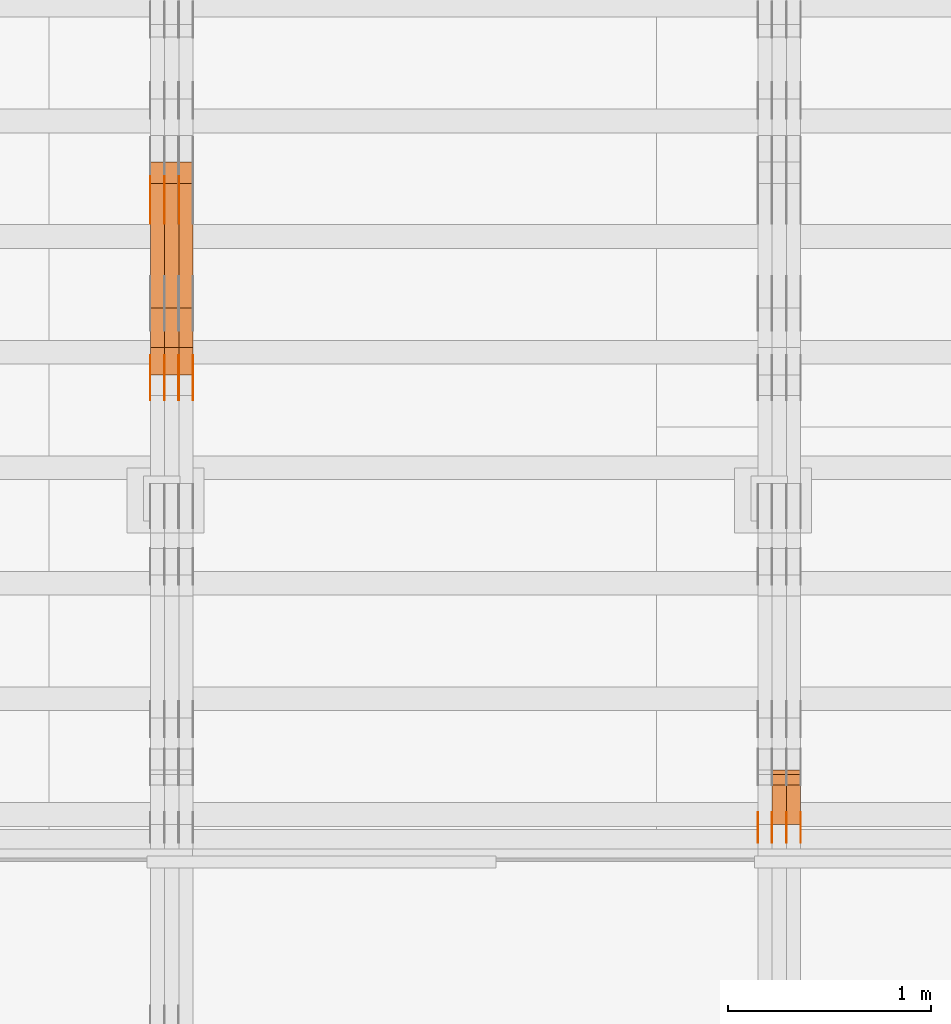
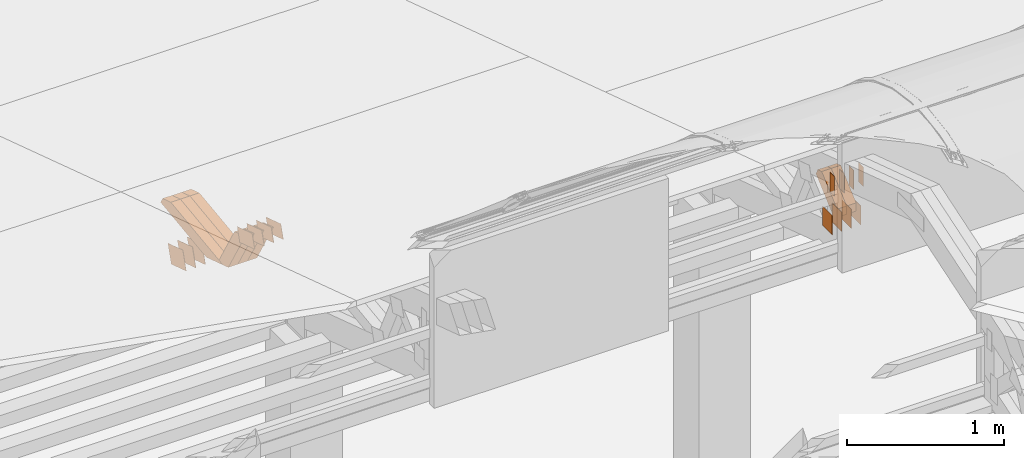
# One storey, part 166 of 385: 30 proxies.
"""IFC2X3 building model written with IfcOpenShell, lengths in millimetres."""

from ifc_helpers import new_model, entity, si_unit, converted_unit, derived_unit, direction, frame, origin, origin_2d_with_axis, place, context, subcontext, project, spatial, polyline, rectangle, outline, extrude, source, transform, mapped, material, type_object, type_shapes, element, save


model = new_model("IFC2X3")

# Units and contexts
model_context = context("Model", 3, precision=0.01, world=origin(), true_north=direction((6.12303176911189e-17, 1.0)))
body_context = subcontext(model_context, "Body", "Model", "MODEL_VIEW")
ifc_project = project(units=[si_unit("LENGTHUNIT", "METRE", prefix="MILLI"), si_unit("AREAUNIT", "SQUARE_METRE"), si_unit("VOLUMEUNIT", "CUBIC_METRE"), converted_unit("PLANEANGLEUNIT", "DEGREE", entity("IfcRatioMeasure", 0.0174532925199433), si_unit("PLANEANGLEUNIT", "RADIAN"), dimensions=[0, 0, 0, 0, 0, 0, 0]), si_unit("MASSUNIT", "GRAM", prefix="KILO"), derived_unit("MASSDENSITYUNIT", [(si_unit("MASSUNIT", "GRAM", prefix="KILO"), 1), (si_unit("LENGTHUNIT", "METRE"), -3)]), si_unit("TIMEUNIT", "SECOND"), si_unit("FREQUENCYUNIT", "HERTZ"), si_unit("THERMODYNAMICTEMPERATUREUNIT", "DEGREE_CELSIUS"), derived_unit("THERMALTRANSMITTANCEUNIT", [(si_unit("MASSUNIT", "GRAM", prefix="KILO"), 1), (si_unit("THERMODYNAMICTEMPERATUREUNIT", "KELVIN"), -1), (si_unit("TIMEUNIT", "SECOND"), -3)]), derived_unit("VOLUMETRICFLOWRATEUNIT", [(si_unit("LENGTHUNIT", "METRE"), 3), (si_unit("TIMEUNIT", "SECOND"), -1)]), si_unit("ELECTRICCURRENTUNIT", "AMPERE"), si_unit("ELECTRICVOLTAGEUNIT", "VOLT"), si_unit("POWERUNIT", "WATT"), si_unit("FORCEUNIT", "NEWTON", prefix="KILO"), si_unit("ILLUMINANCEUNIT", "LUX"), si_unit("LUMINOUSFLUXUNIT", "LUMEN"), si_unit("LUMINOUSINTENSITYUNIT", "CANDELA"), derived_unit("USERDEFINED", [(si_unit("MASSUNIT", "GRAM", prefix="KILO"), -1), (si_unit("LENGTHUNIT", "METRE"), -2), (si_unit("TIMEUNIT", "SECOND"), 3), (si_unit("LUMINOUSFLUXUNIT", "LUMEN"), 1)]), derived_unit("LINEARVELOCITYUNIT", [(si_unit("LENGTHUNIT", "METRE"), 1), (si_unit("TIMEUNIT", "SECOND"), -1)]), si_unit("PRESSUREUNIT", "PASCAL"), derived_unit("USERDEFINED", [(si_unit("LENGTHUNIT", "METRE"), -2), (si_unit("MASSUNIT", "GRAM", prefix="KILO"), 1), (si_unit("TIMEUNIT", "SECOND"), -2)])], contexts=[model_context])

# Site, building, storey
site_placement = place(None, origin())
site = spatial("IfcSite", under=ifc_project, at=site_placement, CompositionType="ELEMENT")
building_placement = place(site_placement, origin())
building = spatial("IfcBuilding", under=site, at=building_placement, CompositionType="ELEMENT")
storey_placement = place(building_placement, origin())
storey = spatial("IfcBuildingStorey", under=building, at=storey_placement, Name="Default", CompositionType="ELEMENT", Elevation=0.0)

# Proxies
ifc_material_1 = material(Name="IfcSurfaceStyle #377538")
building_element_proxy_type_1 = type_object("IfcBuildingElementProxyType", PredefinedType="NOTDEFINED", material=ifc_material_1)
shared_shape_1 = source(origin(), body_context, "Body", "SweptSolid", [
    extrude(rectangle(XDim=150.0, YDim=120.0, at=origin_2d_with_axis()), frame((75.0, 60.0, 0.0), z_axis=(0.0, 0.0, 1.0), x_axis=(-1.0, 0.0, 0.0)), (0.0, 0.0, 1.0), 1.3),
])
type_shapes(building_element_proxy_type_1, [shared_shape_1])
proxy_1_placement = place(building_placement, frame((30386.3, 15840.0, 3652.70166015625), z_axis=(-1.0, 0.0, 0.0), x_axis=(0.0, 0.0, -1.0)))
element("IfcBuildingElementProxy", 1, at=proxy_1_placement, inside=storey, type_object=building_element_proxy_type_1, material=ifc_material_1, context=body_context, shape_type="MappedRepresentation", body=[
    mapped(shared_shape_1, transform((0.0, 0.0, 0.0), scale=1.0)),
])
ifc_material_2 = material(Name="IfcSurfaceStyle #377481")
building_element_proxy_type_2 = type_object("IfcBuildingElementProxyType", PredefinedType="NOTDEFINED", material=ifc_material_2)
shared_shape_2 = source(origin(), body_context, "Body", "SweptSolid", [
    extrude(rectangle(XDim=150.0, YDim=120.0, at=origin_2d_with_axis()), frame((75.0, 60.0, 0.0), z_axis=(0.0, 0.0, 1.0), x_axis=(-1.0, 0.0, 0.0)), (0.0, 0.0, 1.0), 1.3),
])
type_shapes(building_element_proxy_type_2, [shared_shape_2])
proxy_2_placement = place(building_placement, frame((30315.0, 15840.0, 3652.70166015625), z_axis=(-1.0, 0.0, 0.0), x_axis=(0.0, 0.0, -1.0)))
element("IfcBuildingElementProxy", 2, at=proxy_2_placement, inside=storey, type_object=building_element_proxy_type_2, material=ifc_material_2, context=body_context, shape_type="MappedRepresentation", body=[
    mapped(shared_shape_2, transform((0.0, 0.0, 0.0), scale=1.0)),
])
ifc_material_3 = material(Name="IfcSurfaceStyle #377424")
building_element_proxy_type_3 = type_object("IfcBuildingElementProxyType", PredefinedType="NOTDEFINED", material=ifc_material_3)
shared_shape_3 = source(origin(), body_context, "Body", "SweptSolid", [
    extrude(rectangle(XDim=150.0, YDim=120.0, at=origin_2d_with_axis()), frame((75.0, 60.0, 0.0), z_axis=(0.0, 0.0, 1.0), x_axis=(-1.0, 0.0, 0.0)), (0.0, 0.0, 1.0), 1.3),
])
type_shapes(building_element_proxy_type_3, [shared_shape_3])
proxy_3_placement = place(building_placement, frame((30316.3, 15840.0, 3652.70166015625), z_axis=(-1.0, 0.0, 0.0), x_axis=(0.0, 0.0, -1.0)))
element("IfcBuildingElementProxy", 3, at=proxy_3_placement, inside=storey, type_object=building_element_proxy_type_3, material=ifc_material_3, context=body_context, shape_type="MappedRepresentation", body=[
    mapped(shared_shape_3, transform((0.0, 0.0, 0.0), scale=1.0)),
])
ifc_material_4 = material(Name="IfcSurfaceStyle #377367")
building_element_proxy_type_4 = type_object("IfcBuildingElementProxyType", PredefinedType="NOTDEFINED", material=ifc_material_4)
shared_shape_4 = source(origin(), body_context, "Body", "SweptSolid", [
    extrude(rectangle(XDim=150.0, YDim=120.0, at=origin_2d_with_axis()), frame((75.0, 60.0, 0.0), z_axis=(0.0, 0.0, 1.0), x_axis=(-1.0, 0.0, 0.0)), (0.0, 0.0, 1.0), 1.29999999999999),
])
type_shapes(building_element_proxy_type_4, [shared_shape_4])
proxy_4_placement = place(building_placement, frame((30245.0, 15840.0, 3652.70166015625), z_axis=(-1.0, 0.0, 0.0), x_axis=(0.0, 0.0, -1.0)))
element("IfcBuildingElementProxy", 4, at=proxy_4_placement, inside=storey, type_object=building_element_proxy_type_4, material=ifc_material_4, context=body_context, shape_type="MappedRepresentation", body=[
    mapped(shared_shape_4, transform((0.0, 0.0, 0.0), scale=1.0)),
])
ifc_material_5 = material(Name="IfcSurfaceStyle #377310")
building_element_proxy_type_5 = type_object("IfcBuildingElementProxyType", PredefinedType="NOTDEFINED", material=ifc_material_5)
shared_shape_5 = source(origin(), body_context, "Body", "SweptSolid", [
    extrude(rectangle(XDim=150.0, YDim=120.0, at=origin_2d_with_axis()), frame((75.0, 60.0, 0.0), z_axis=(0.0, 0.0, 1.0), x_axis=(-1.0, 0.0, 0.0)), (0.0, 0.0, 1.0), 1.29999999999999),
])
type_shapes(building_element_proxy_type_5, [shared_shape_5])
proxy_5_placement = place(building_placement, frame((30246.3, 15840.0, 3652.70166015625), z_axis=(-1.0, 0.0, 0.0), x_axis=(0.0, 0.0, -1.0)))
element("IfcBuildingElementProxy", 5, at=proxy_5_placement, inside=storey, type_object=building_element_proxy_type_5, material=ifc_material_5, context=body_context, shape_type="MappedRepresentation", body=[
    mapped(shared_shape_5, transform((0.0, 0.0, 0.0), scale=1.0)),
])
ifc_material_6 = material(Name="IfcSurfaceStyle #377253")
building_element_proxy_type_6 = type_object("IfcBuildingElementProxyType", PredefinedType="NOTDEFINED", material=ifc_material_6)
shared_shape_6 = source(origin(), body_context, "Body", "SweptSolid", [
    extrude(rectangle(XDim=150.0, YDim=120.0, at=origin_2d_with_axis()), frame((75.0, 60.0, 0.0), z_axis=(0.0, 0.0, 1.0), x_axis=(-1.0, 0.0, 0.0)), (0.0, 0.0, 1.0), 1.29999999999999),
])
type_shapes(building_element_proxy_type_6, [shared_shape_6])
proxy_6_placement = place(building_placement, frame((30175.0, 15840.0, 3652.70166015625), z_axis=(-1.0, 0.0, 0.0), x_axis=(0.0, 0.0, -1.0)))
element("IfcBuildingElementProxy", 6, at=proxy_6_placement, inside=storey, type_object=building_element_proxy_type_6, material=ifc_material_6, context=body_context, shape_type="MappedRepresentation", body=[
    mapped(shared_shape_6, transform((0.0, 0.0, 0.0), scale=1.0)),
])
ifc_material_7 = material(Name="IfcSurfaceStyle #372066")
building_element_proxy_type_7 = type_object("IfcBuildingElementProxyType", PredefinedType="NOTDEFINED", material=ifc_material_7)
shared_shape_7 = source(origin(), body_context, "Body", "SweptSolid", [
    extrude(rectangle(XDim=150.0, YDim=60.0, at=origin_2d_with_axis()), frame((75.0000705696311, 30.0, 0.0), z_axis=(0.0, 0.0, 1.0), x_axis=(-1.0, 0.0, 0.0)), (0.0, 0.0, 1.0), 1.3),
])
type_shapes(building_element_proxy_type_7, [shared_shape_7])
proxy_7_placement = place(building_placement, frame((30386.3, 15750.0, 3972.59919166338), z_axis=(-1.0, 0.0, 0.0), x_axis=(0.0, 0.0, -1.0)))
element("IfcBuildingElementProxy", 7, at=proxy_7_placement, inside=storey, type_object=building_element_proxy_type_7, material=ifc_material_7, context=body_context, shape_type="MappedRepresentation", body=[
    mapped(shared_shape_7, transform((0.0, 0.0, 0.0), scale=1.0)),
])
ifc_material_8 = material(Name="IfcSurfaceStyle #372009")
building_element_proxy_type_8 = type_object("IfcBuildingElementProxyType", PredefinedType="NOTDEFINED", material=ifc_material_8)
shared_shape_8 = source(origin(), body_context, "Body", "SweptSolid", [
    extrude(rectangle(XDim=150.0, YDim=60.0, at=origin_2d_with_axis()), frame((75.0000705696311, 30.0, 0.0), z_axis=(0.0, 0.0, 1.0), x_axis=(-1.0, 0.0, 0.0)), (0.0, 0.0, 1.0), 1.3),
])
type_shapes(building_element_proxy_type_8, [shared_shape_8])
proxy_8_placement = place(building_placement, frame((30315.0, 15750.0, 3972.59919166338), z_axis=(-1.0, 0.0, 0.0), x_axis=(0.0, 0.0, -1.0)))
element("IfcBuildingElementProxy", 8, at=proxy_8_placement, inside=storey, type_object=building_element_proxy_type_8, material=ifc_material_8, context=body_context, shape_type="MappedRepresentation", body=[
    mapped(shared_shape_8, transform((0.0, 0.0, 0.0), scale=1.0)),
])
ifc_material_9 = material(Name="IfcSurfaceStyle #371952")
building_element_proxy_type_9 = type_object("IfcBuildingElementProxyType", PredefinedType="NOTDEFINED", material=ifc_material_9)
shared_shape_9 = source(origin(), body_context, "Body", "SweptSolid", [
    extrude(rectangle(XDim=150.0, YDim=60.0, at=origin_2d_with_axis()), frame((75.0000705696311, 30.0, 0.0), z_axis=(0.0, 0.0, 1.0), x_axis=(-1.0, 0.0, 0.0)), (0.0, 0.0, 1.0), 1.3),
])
type_shapes(building_element_proxy_type_9, [shared_shape_9])
proxy_9_placement = place(building_placement, frame((30316.3, 15750.0, 3972.59919166338), z_axis=(-1.0, 0.0, 0.0), x_axis=(0.0, 0.0, -1.0)))
element("IfcBuildingElementProxy", 9, at=proxy_9_placement, inside=storey, type_object=building_element_proxy_type_9, material=ifc_material_9, context=body_context, shape_type="MappedRepresentation", body=[
    mapped(shared_shape_9, transform((0.0, 0.0, 0.0), scale=1.0)),
])
ifc_material_10 = material(Name="IfcSurfaceStyle #371895")
building_element_proxy_type_10 = type_object("IfcBuildingElementProxyType", PredefinedType="NOTDEFINED", material=ifc_material_10)
shared_shape_10 = source(origin(), body_context, "Body", "SweptSolid", [
    extrude(rectangle(XDim=150.0, YDim=60.0, at=origin_2d_with_axis()), frame((75.0000705696311, 30.0, 0.0), z_axis=(0.0, 0.0, 1.0), x_axis=(-1.0, 0.0, 0.0)), (0.0, 0.0, 1.0), 1.29999999999999),
])
type_shapes(building_element_proxy_type_10, [shared_shape_10])
proxy_10_placement = place(building_placement, frame((30245.0, 15750.0, 3972.59919166338), z_axis=(-1.0, 0.0, 0.0), x_axis=(0.0, 0.0, -1.0)))
element("IfcBuildingElementProxy", 10, at=proxy_10_placement, inside=storey, type_object=building_element_proxy_type_10, material=ifc_material_10, context=body_context, shape_type="MappedRepresentation", body=[
    mapped(shared_shape_10, transform((0.0, 0.0, 0.0), scale=1.0)),
])
ifc_material_11 = material(Name="IfcSurfaceStyle #371838")
building_element_proxy_type_11 = type_object("IfcBuildingElementProxyType", PredefinedType="NOTDEFINED", material=ifc_material_11)
shared_shape_11 = source(origin(), body_context, "Body", "SweptSolid", [
    extrude(rectangle(XDim=150.0, YDim=60.0, at=origin_2d_with_axis()), frame((75.0000705696311, 30.0, 0.0), z_axis=(0.0, 0.0, 1.0), x_axis=(-1.0, 0.0, 0.0)), (0.0, 0.0, 1.0), 1.29999999999999),
])
type_shapes(building_element_proxy_type_11, [shared_shape_11])
proxy_11_placement = place(building_placement, frame((30246.3, 15750.0, 3972.59919166338), z_axis=(-1.0, 0.0, 0.0), x_axis=(0.0, 0.0, -1.0)))
element("IfcBuildingElementProxy", 11, at=proxy_11_placement, inside=storey, type_object=building_element_proxy_type_11, material=ifc_material_11, context=body_context, shape_type="MappedRepresentation", body=[
    mapped(shared_shape_11, transform((0.0, 0.0, 0.0), scale=1.0)),
])
ifc_material_12 = material(Name="IfcSurfaceStyle #371781")
building_element_proxy_type_12 = type_object("IfcBuildingElementProxyType", PredefinedType="NOTDEFINED", material=ifc_material_12)
shared_shape_12 = source(origin(), body_context, "Body", "SweptSolid", [
    extrude(rectangle(XDim=150.0, YDim=60.0, at=origin_2d_with_axis()), frame((75.0000705696311, 30.0, 0.0), z_axis=(0.0, 0.0, 1.0), x_axis=(-1.0, 0.0, 0.0)), (0.0, 0.0, 1.0), 1.29999999999999),
])
type_shapes(building_element_proxy_type_12, [shared_shape_12])
proxy_12_placement = place(building_placement, frame((30175.0, 15750.0, 3972.59919166338), z_axis=(-1.0, 0.0, 0.0), x_axis=(0.0, 0.0, -1.0)))
element("IfcBuildingElementProxy", 12, at=proxy_12_placement, inside=storey, type_object=building_element_proxy_type_12, material=ifc_material_12, context=body_context, shape_type="MappedRepresentation", body=[
    mapped(shared_shape_12, transform((0.0, 0.0, 0.0), scale=1.0)),
])
ifc_material_13 = material(Name="IfcSurfaceStyle #362697")
building_element_proxy_type_13 = type_object("IfcBuildingElementProxyType", Name="T1-W50 362695", PredefinedType="NOTDEFINED", material=ifc_material_13)
shared_shape_13 = source(origin(), body_context, "Body", "SweptSolid", [
    extrude(outline(polyline([(-128.56619634284, -47.4999385885712), (133.151257249084, -47.4999385885712), (161.172800006526, -0.000129729183733609), (147.291467726413, 47.500068317755), (-142.513973767368, 47.500068317755), (-170.535354871815, -0.000129729183754689), (-128.56619634284, -47.4999385885712)])), frame((161.17310141218, 47.5001898716564, 0.0), z_axis=(0.0, 0.0, 1.0), x_axis=(-1.0, 0.0, 0.0)), (0.0, 0.0, 1.0), 70.0),
])
type_shapes(building_element_proxy_type_13, [shared_shape_13])
proxy_13_placement = place(building_placement, frame((30385.0, 16060.0297689714, 3761.73994820667), z_axis=(-1.0, 0.0, 0.0), x_axis=(0.0, -0.749388407538668, -0.662130662820156)))
element("IfcBuildingElementProxy", 13, at=proxy_13_placement, inside=storey, type_object=building_element_proxy_type_13, material=ifc_material_13, Name="T1-W50", context=body_context, shape_type="MappedRepresentation", body=[
    mapped(shared_shape_13, transform((0.0, 0.0, 0.0), scale=1.0)),
])
ifc_material_14 = material(Name="IfcSurfaceStyle #362622")
building_element_proxy_type_14 = type_object("IfcBuildingElementProxyType", Name="T1-W50 362620", PredefinedType="NOTDEFINED", material=ifc_material_14)
shared_shape_14 = source(origin(), body_context, "Body", "SweptSolid", [
    extrude(outline(polyline([(-128.56619634284, -47.4999385885712), (133.151257249084, -47.4999385885712), (161.172800006526, -0.000129729183733609), (147.291467726413, 47.500068317755), (-142.513973767368, 47.500068317755), (-170.535354871815, -0.000129729183754689), (-128.56619634284, -47.4999385885712)])), frame((161.17310141218, 47.5001898716564, 0.0), z_axis=(0.0, 0.0, 1.0), x_axis=(-1.0, 0.0, 0.0)), (0.0, 0.0, 1.0), 70.0),
])
type_shapes(building_element_proxy_type_14, [shared_shape_14])
proxy_14_placement = place(building_placement, frame((30315.0, 16060.0297689714, 3761.73994820667), z_axis=(-1.0, 0.0, 0.0), x_axis=(0.0, -0.749388407538668, -0.662130662820156)))
element("IfcBuildingElementProxy", 14, at=proxy_14_placement, inside=storey, type_object=building_element_proxy_type_14, material=ifc_material_14, Name="T1-W50", context=body_context, shape_type="MappedRepresentation", body=[
    mapped(shared_shape_14, transform((0.0, 0.0, 0.0), scale=1.0)),
])
ifc_material_15 = material(Name="IfcSurfaceStyle #340598")
building_element_proxy_type_15 = type_object("IfcBuildingElementProxyType", PredefinedType="NOTDEFINED", material=ifc_material_15)
shared_shape_15 = source(origin(), body_context, "Body", "SweptSolid", [
    extrude(outline(polyline([(-99.999796294464, -72.0000050220467), (99.9998768370438, -72.0000050220467), (100.000260677528, 72.0000050220467), (-100.000341220108, 72.0000050220467), (-99.999796294464, -72.0000050220467)])), frame((100.000260677528, 72.0000050220467, 0.0), z_axis=(0.0, 0.0, 1.0), x_axis=(-1.0, 0.0, 0.0)), (0.0, 0.0, 1.0), 1.3),
])
type_shapes(building_element_proxy_type_15, [shared_shape_15])
proxy_15_placement = place(building_placement, frame((27316.3, 18936.3876569477, 2373.90613192527), z_axis=(-1.0, 0.0, 0.0), x_axis=(0.0, -0.951056516295124, 0.309016994375039)))
element("IfcBuildingElementProxy", 15, at=proxy_15_placement, inside=storey, type_object=building_element_proxy_type_15, material=ifc_material_15, context=body_context, shape_type="MappedRepresentation", body=[
    mapped(shared_shape_15, transform((0.0, 0.0, 0.0), scale=1.0)),
])
ifc_material_16 = material(Name="IfcSurfaceStyle #340541")
building_element_proxy_type_16 = type_object("IfcBuildingElementProxyType", PredefinedType="NOTDEFINED", material=ifc_material_16)
shared_shape_16 = source(origin(), body_context, "Body", "SweptSolid", [
    extrude(outline(polyline([(-99.999796294464, -72.0000050220467), (99.9998768370438, -72.0000050220467), (100.000260677528, 72.0000050220467), (-100.000341220108, 72.0000050220467), (-99.999796294464, -72.0000050220467)])), frame((100.000260677528, 72.0000050220467, 0.0), z_axis=(0.0, 0.0, 1.0), x_axis=(-1.0, 0.0, 0.0)), (0.0, 0.0, 1.0), 1.29999999999998),
])
type_shapes(building_element_proxy_type_16, [shared_shape_16])
proxy_16_placement = place(building_placement, frame((27245.0, 18936.3876569477, 2373.90613192527), z_axis=(-1.0, 0.0, 0.0), x_axis=(0.0, -0.951056516295124, 0.309016994375039)))
element("IfcBuildingElementProxy", 16, at=proxy_16_placement, inside=storey, type_object=building_element_proxy_type_16, material=ifc_material_16, context=body_context, shape_type="MappedRepresentation", body=[
    mapped(shared_shape_16, transform((0.0, 0.0, 0.0), scale=1.0)),
])
ifc_material_17 = material(Name="IfcSurfaceStyle #340484")
building_element_proxy_type_17 = type_object("IfcBuildingElementProxyType", PredefinedType="NOTDEFINED", material=ifc_material_17)
shared_shape_17 = source(origin(), body_context, "Body", "SweptSolid", [
    extrude(outline(polyline([(-99.999796294464, -72.0000050220467), (99.9998768370438, -72.0000050220467), (100.000260677528, 72.0000050220467), (-100.000341220108, 72.0000050220467), (-99.999796294464, -72.0000050220467)])), frame((100.000260677528, 72.0000050220467, 0.0), z_axis=(0.0, 0.0, 1.0), x_axis=(-1.0, 0.0, 0.0)), (0.0, 0.0, 1.0), 1.29999999999998),
])
type_shapes(building_element_proxy_type_17, [shared_shape_17])
proxy_17_placement = place(building_placement, frame((27246.3, 18936.3876569477, 2373.90613192527), z_axis=(-1.0, 0.0, 0.0), x_axis=(0.0, -0.951056516295124, 0.309016994375039)))
element("IfcBuildingElementProxy", 17, at=proxy_17_placement, inside=storey, type_object=building_element_proxy_type_17, material=ifc_material_17, context=body_context, shape_type="MappedRepresentation", body=[
    mapped(shared_shape_17, transform((0.0, 0.0, 0.0), scale=1.0)),
])
ifc_material_18 = material(Name="IfcSurfaceStyle #340427")
building_element_proxy_type_18 = type_object("IfcBuildingElementProxyType", PredefinedType="NOTDEFINED", material=ifc_material_18)
shared_shape_18 = source(origin(), body_context, "Body", "SweptSolid", [
    extrude(outline(polyline([(-99.999796294464, -72.0000050220467), (99.9998768370438, -72.0000050220467), (100.000260677528, 72.0000050220467), (-100.000341220108, 72.0000050220467), (-99.999796294464, -72.0000050220467)])), frame((100.000260677528, 72.0000050220467, 0.0), z_axis=(0.0, 0.0, 1.0), x_axis=(-1.0, 0.0, 0.0)), (0.0, 0.0, 1.0), 1.29999999999999),
])
type_shapes(building_element_proxy_type_18, [shared_shape_18])
proxy_18_placement = place(building_placement, frame((27175.0, 18936.3876569477, 2373.90613192527), z_axis=(-1.0, 0.0, 0.0), x_axis=(0.0, -0.951056516295124, 0.309016994375039)))
element("IfcBuildingElementProxy", 18, at=proxy_18_placement, inside=storey, type_object=building_element_proxy_type_18, material=ifc_material_18, context=body_context, shape_type="MappedRepresentation", body=[
    mapped(shared_shape_18, transform((0.0, 0.0, 0.0), scale=1.0)),
])
ifc_material_19 = material(Name="IfcSurfaceStyle #336266")
building_element_proxy_type_19 = type_object("IfcBuildingElementProxyType", PredefinedType="NOTDEFINED", material=ifc_material_19)
shared_shape_19 = source(origin(), body_context, "Body", "SweptSolid", [
    extrude(outline(polyline([(-99.9999427841299, -54.0000599375792), (99.9996549037756, -54.0000599375792), (100.000407167194, 54.0000599375792), (-100.00011928684, 54.0000599375792), (-99.9999427841299, -54.0000599375792)])), frame((100.000407167194, 54.0000599375792, 0.0), z_axis=(0.0, 0.0, 1.0), x_axis=(-1.0, 0.0, 0.0)), (0.0, 0.0, 1.0), 1.3),
])
type_shapes(building_element_proxy_type_19, [shared_shape_19])
proxy_19_placement = place(building_placement, frame((27386.3, 18065.0682492591, 3072.55239547302), z_axis=(-1.0, 0.0, 0.0), x_axis=(0.0, -0.951056516295154, 0.309016994374948)))
element("IfcBuildingElementProxy", 19, at=proxy_19_placement, inside=storey, type_object=building_element_proxy_type_19, material=ifc_material_19, context=body_context, shape_type="MappedRepresentation", body=[
    mapped(shared_shape_19, transform((0.0, 0.0, 0.0), scale=1.0)),
])
ifc_material_20 = material(Name="IfcSurfaceStyle #336209")
building_element_proxy_type_20 = type_object("IfcBuildingElementProxyType", PredefinedType="NOTDEFINED", material=ifc_material_20)
shared_shape_20 = source(origin(), body_context, "Body", "SweptSolid", [
    extrude(outline(polyline([(-99.9999427841299, -54.0000599375792), (99.9996549037756, -54.0000599375792), (100.000407167194, 54.0000599375792), (-100.00011928684, 54.0000599375792), (-99.9999427841299, -54.0000599375792)])), frame((100.000407167194, 54.0000599375792, 0.0), z_axis=(0.0, 0.0, 1.0), x_axis=(-1.0, 0.0, 0.0)), (0.0, 0.0, 1.0), 1.3),
])
type_shapes(building_element_proxy_type_20, [shared_shape_20])
proxy_20_placement = place(building_placement, frame((27315.0, 18065.0682492591, 3072.55239547302), z_axis=(-1.0, 0.0, 0.0), x_axis=(0.0, -0.951056516295154, 0.309016994374948)))
element("IfcBuildingElementProxy", 20, at=proxy_20_placement, inside=storey, type_object=building_element_proxy_type_20, material=ifc_material_20, context=body_context, shape_type="MappedRepresentation", body=[
    mapped(shared_shape_20, transform((0.0, 0.0, 0.0), scale=1.0)),
])
ifc_material_21 = material(Name="IfcSurfaceStyle #336152")
building_element_proxy_type_21 = type_object("IfcBuildingElementProxyType", PredefinedType="NOTDEFINED", material=ifc_material_21)
shared_shape_21 = source(origin(), body_context, "Body", "SweptSolid", [
    extrude(outline(polyline([(-99.9999427841299, -54.0000599375792), (99.9996549037756, -54.0000599375792), (100.000407167194, 54.0000599375792), (-100.00011928684, 54.0000599375792), (-99.9999427841299, -54.0000599375792)])), frame((100.000407167194, 54.0000599375792, 0.0), z_axis=(0.0, 0.0, 1.0), x_axis=(-1.0, 0.0, 0.0)), (0.0, 0.0, 1.0), 1.3),
])
type_shapes(building_element_proxy_type_21, [shared_shape_21])
proxy_21_placement = place(building_placement, frame((27316.3, 18065.0682492591, 3072.55239547302), z_axis=(-1.0, 0.0, 0.0), x_axis=(0.0, -0.951056516295154, 0.309016994374948)))
element("IfcBuildingElementProxy", 21, at=proxy_21_placement, inside=storey, type_object=building_element_proxy_type_21, material=ifc_material_21, context=body_context, shape_type="MappedRepresentation", body=[
    mapped(shared_shape_21, transform((0.0, 0.0, 0.0), scale=1.0)),
])
ifc_material_22 = material(Name="IfcSurfaceStyle #336095")
building_element_proxy_type_22 = type_object("IfcBuildingElementProxyType", PredefinedType="NOTDEFINED", material=ifc_material_22)
shared_shape_22 = source(origin(), body_context, "Body", "SweptSolid", [
    extrude(outline(polyline([(-99.9999427841299, -54.0000599375792), (99.9996549037756, -54.0000599375792), (100.000407167194, 54.0000599375792), (-100.00011928684, 54.0000599375792), (-99.9999427841299, -54.0000599375792)])), frame((100.000407167194, 54.0000599375792, 0.0), z_axis=(0.0, 0.0, 1.0), x_axis=(-1.0, 0.0, 0.0)), (0.0, 0.0, 1.0), 1.29999999999998),
])
type_shapes(building_element_proxy_type_22, [shared_shape_22])
proxy_22_placement = place(building_placement, frame((27245.0, 18065.0682492591, 3072.55239547302), z_axis=(-1.0, 0.0, 0.0), x_axis=(0.0, -0.951056516295154, 0.309016994374948)))
element("IfcBuildingElementProxy", 22, at=proxy_22_placement, inside=storey, type_object=building_element_proxy_type_22, material=ifc_material_22, context=body_context, shape_type="MappedRepresentation", body=[
    mapped(shared_shape_22, transform((0.0, 0.0, 0.0), scale=1.0)),
])
ifc_material_23 = material(Name="IfcSurfaceStyle #336038")
building_element_proxy_type_23 = type_object("IfcBuildingElementProxyType", PredefinedType="NOTDEFINED", material=ifc_material_23)
shared_shape_23 = source(origin(), body_context, "Body", "SweptSolid", [
    extrude(outline(polyline([(-99.9999427841299, -54.0000599375792), (99.9996549037756, -54.0000599375792), (100.000407167194, 54.0000599375792), (-100.00011928684, 54.0000599375792), (-99.9999427841299, -54.0000599375792)])), frame((100.000407167194, 54.0000599375792, 0.0), z_axis=(0.0, 0.0, 1.0), x_axis=(-1.0, 0.0, 0.0)), (0.0, 0.0, 1.0), 1.29999999999998),
])
type_shapes(building_element_proxy_type_23, [shared_shape_23])
proxy_23_placement = place(building_placement, frame((27246.3, 18065.0682492591, 3072.55239547302), z_axis=(-1.0, 0.0, 0.0), x_axis=(0.0, -0.951056516295154, 0.309016994374948)))
element("IfcBuildingElementProxy", 23, at=proxy_23_placement, inside=storey, type_object=building_element_proxy_type_23, material=ifc_material_23, context=body_context, shape_type="MappedRepresentation", body=[
    mapped(shared_shape_23, transform((0.0, 0.0, 0.0), scale=1.0)),
])
ifc_material_24 = material(Name="IfcSurfaceStyle #335981")
building_element_proxy_type_24 = type_object("IfcBuildingElementProxyType", PredefinedType="NOTDEFINED", material=ifc_material_24)
shared_shape_24 = source(origin(), body_context, "Body", "SweptSolid", [
    extrude(outline(polyline([(-99.9999427841299, -54.0000599375792), (99.9996549037756, -54.0000599375792), (100.000407167194, 54.0000599375792), (-100.00011928684, 54.0000599375792), (-99.9999427841299, -54.0000599375792)])), frame((100.000407167194, 54.0000599375792, 0.0), z_axis=(0.0, 0.0, 1.0), x_axis=(-1.0, 0.0, 0.0)), (0.0, 0.0, 1.0), 1.29999999999999),
])
type_shapes(building_element_proxy_type_24, [shared_shape_24])
proxy_24_placement = place(building_placement, frame((27175.0, 18065.0682492591, 3072.55239547302), z_axis=(-1.0, 0.0, 0.0), x_axis=(0.0, -0.951056516295154, 0.309016994374948)))
element("IfcBuildingElementProxy", 24, at=proxy_24_placement, inside=storey, type_object=building_element_proxy_type_24, material=ifc_material_24, context=body_context, shape_type="MappedRepresentation", body=[
    mapped(shared_shape_24, transform((0.0, 0.0, 0.0), scale=1.0)),
])
ifc_material_25 = material(Name="IfcSurfaceStyle #326114")
building_element_proxy_type_25 = type_object("IfcBuildingElementProxyType", Name="T1-W35 326112", PredefinedType="NOTDEFINED", material=ifc_material_25)
shared_shape_25 = source(origin(), body_context, "Body", "SweptSolid", [
    extrude(outline(polyline([(-196.877231354918, -47.499850828051), (197.289756738813, -47.499850828051), (177.380838136073, -0.000131002767018074), (124.615181369032, 47.4999163294346), (-302.408544889, 47.4999163294346), (-196.877231354918, -47.499850828051)])), frame((197.289756738813, 47.5002438363521, 0.0), z_axis=(0.0, 0.0, 1.0), x_axis=(-1.0, 0.0, 0.0)), (0.0, 0.0, 1.0), 70.0),
])
type_shapes(building_element_proxy_type_25, [shared_shape_25])
proxy_25_placement = place(building_placement, frame((27385.0, 18249.5528960018, 2724.16980022534), z_axis=(-1.0, 0.0, 0.0), x_axis=(0.0, -0.5, 0.866025403784439)))
element("IfcBuildingElementProxy", 25, at=proxy_25_placement, inside=storey, type_object=building_element_proxy_type_25, material=ifc_material_25, Name="T1-W35", context=body_context, shape_type="MappedRepresentation", body=[
    mapped(shared_shape_25, transform((0.0, 0.0, 0.0), scale=1.0)),
])
ifc_material_26 = material(Name="IfcSurfaceStyle #326048")
building_element_proxy_type_26 = type_object("IfcBuildingElementProxyType", Name="T1-W35 326046", PredefinedType="NOTDEFINED", material=ifc_material_26)
shared_shape_26 = source(origin(), body_context, "Body", "SweptSolid", [
    extrude(outline(polyline([(-196.877231354918, -47.499850828051), (197.289756738813, -47.499850828051), (177.380838136073, -0.000131002767018074), (124.615181369032, 47.4999163294346), (-302.408544889, 47.4999163294346), (-196.877231354918, -47.499850828051)])), frame((197.289756738813, 47.5002438363521, 0.0), z_axis=(0.0, 0.0, 1.0), x_axis=(-1.0, 0.0, 0.0)), (0.0, 0.0, 1.0), 70.0),
])
type_shapes(building_element_proxy_type_26, [shared_shape_26])
proxy_26_placement = place(building_placement, frame((27315.0, 18249.5528960018, 2724.16980022534), z_axis=(-1.0, 0.0, 0.0), x_axis=(0.0, -0.5, 0.866025403784439)))
element("IfcBuildingElementProxy", 26, at=proxy_26_placement, inside=storey, type_object=building_element_proxy_type_26, material=ifc_material_26, Name="T1-W35", context=body_context, shape_type="MappedRepresentation", body=[
    mapped(shared_shape_26, transform((0.0, 0.0, 0.0), scale=1.0)),
])
ifc_material_27 = material(Name="IfcSurfaceStyle #325982")
building_element_proxy_type_27 = type_object("IfcBuildingElementProxyType", Name="T1-W35 325980", PredefinedType="NOTDEFINED", material=ifc_material_27)
shared_shape_27 = source(origin(), body_context, "Body", "SweptSolid", [
    extrude(outline(polyline([(-196.877231354918, -47.499850828051), (197.289756738813, -47.499850828051), (177.380838136073, -0.000131002767018074), (124.615181369032, 47.4999163294346), (-302.408544889, 47.4999163294346), (-196.877231354918, -47.499850828051)])), frame((197.289756738813, 47.5002438363521, 0.0), z_axis=(0.0, 0.0, 1.0), x_axis=(-1.0, 0.0, 0.0)), (0.0, 0.0, 1.0), 70.0),
])
type_shapes(building_element_proxy_type_27, [shared_shape_27])
proxy_27_placement = place(building_placement, frame((27245.0, 18249.5528960018, 2724.16980022534), z_axis=(-1.0, 0.0, 0.0), x_axis=(0.0, -0.5, 0.866025403784439)))
element("IfcBuildingElementProxy", 27, at=proxy_27_placement, inside=storey, type_object=building_element_proxy_type_27, material=ifc_material_27, Name="T1-W35", context=body_context, shape_type="MappedRepresentation", body=[
    mapped(shared_shape_27, transform((0.0, 0.0, 0.0), scale=1.0)),
])
ifc_material_28 = material(Name="IfcSurfaceStyle #325718")
building_element_proxy_type_28 = type_object("IfcBuildingElementProxyType", Name="T1-W6 325716", PredefinedType="NOTDEFINED", material=ifc_material_28)
shared_shape_28 = source(origin(), body_context, "Body", "SweptSolid", [
    extrude(outline(polyline([(-485.945461934772, -47.500204767976), (183.41906495488, -47.500204767976), (284.061400026172, 0.000179660053988773), (303.127757064591, 47.500114937949), (-284.66276011087, 47.500114937949), (-485.945461934772, -47.500204767976)])), frame((303.127970456024, 47.5001450766485, 0.0), z_axis=(0.0, 0.0, 1.0), x_axis=(-1.0, 0.0, 0.0)), (0.0, 0.0, 1.0), 70.0),
])
type_shapes(building_element_proxy_type_28, [shared_shape_28])
proxy_28_placement = place(building_placement, frame((27385.0, 19075.4826373647, 2770.72729201433), z_axis=(-1.0, 0.0, 0.0), x_axis=(0.0, -0.991969529622927, -0.126477082112413)))
element("IfcBuildingElementProxy", 28, at=proxy_28_placement, inside=storey, type_object=building_element_proxy_type_28, material=ifc_material_28, Name="T1-W6", context=body_context, shape_type="MappedRepresentation", body=[
    mapped(shared_shape_28, transform((0.0, 0.0, 0.0), scale=1.0)),
])
ifc_material_29 = material(Name="IfcSurfaceStyle #325652")
building_element_proxy_type_29 = type_object("IfcBuildingElementProxyType", Name="T1-W6 325650", PredefinedType="NOTDEFINED", material=ifc_material_29)
shared_shape_29 = source(origin(), body_context, "Body", "SweptSolid", [
    extrude(outline(polyline([(-485.945461934772, -47.500204767976), (183.41906495488, -47.500204767976), (284.061400026172, 0.000179660053988773), (303.127757064591, 47.500114937949), (-284.66276011087, 47.500114937949), (-485.945461934772, -47.500204767976)])), frame((303.127970456024, 47.5001450766485, 0.0), z_axis=(0.0, 0.0, 1.0), x_axis=(-1.0, 0.0, 0.0)), (0.0, 0.0, 1.0), 70.0),
])
type_shapes(building_element_proxy_type_29, [shared_shape_29])
proxy_29_placement = place(building_placement, frame((27315.0, 19075.4826373647, 2770.72729201433), z_axis=(-1.0, 0.0, 0.0), x_axis=(0.0, -0.991969529622927, -0.126477082112413)))
element("IfcBuildingElementProxy", 29, at=proxy_29_placement, inside=storey, type_object=building_element_proxy_type_29, material=ifc_material_29, Name="T1-W6", context=body_context, shape_type="MappedRepresentation", body=[
    mapped(shared_shape_29, transform((0.0, 0.0, 0.0), scale=1.0)),
])
ifc_material_30 = material(Name="IfcSurfaceStyle #325586")
building_element_proxy_type_30 = type_object("IfcBuildingElementProxyType", Name="T1-W6 325584", PredefinedType="NOTDEFINED", material=ifc_material_30)
shared_shape_30 = source(origin(), body_context, "Body", "SweptSolid", [
    extrude(outline(polyline([(-485.945461934772, -47.500204767976), (183.41906495488, -47.500204767976), (284.061400026172, 0.000179660053988773), (303.127757064591, 47.500114937949), (-284.66276011087, 47.500114937949), (-485.945461934772, -47.500204767976)])), frame((303.127970456024, 47.5001450766485, 0.0), z_axis=(0.0, 0.0, 1.0), x_axis=(-1.0, 0.0, 0.0)), (0.0, 0.0, 1.0), 70.0),
])
type_shapes(building_element_proxy_type_30, [shared_shape_30])
proxy_30_placement = place(building_placement, frame((27245.0, 19075.4826373647, 2770.72729201433), z_axis=(-1.0, 0.0, 0.0), x_axis=(0.0, -0.991969529622927, -0.126477082112413)))
element("IfcBuildingElementProxy", 30, at=proxy_30_placement, inside=storey, type_object=building_element_proxy_type_30, material=ifc_material_30, Name="T1-W6", context=body_context, shape_type="MappedRepresentation", body=[
    mapped(shared_shape_30, transform((0.0, 0.0, 0.0), scale=1.0)),
])

save(model, "model.ifc")
